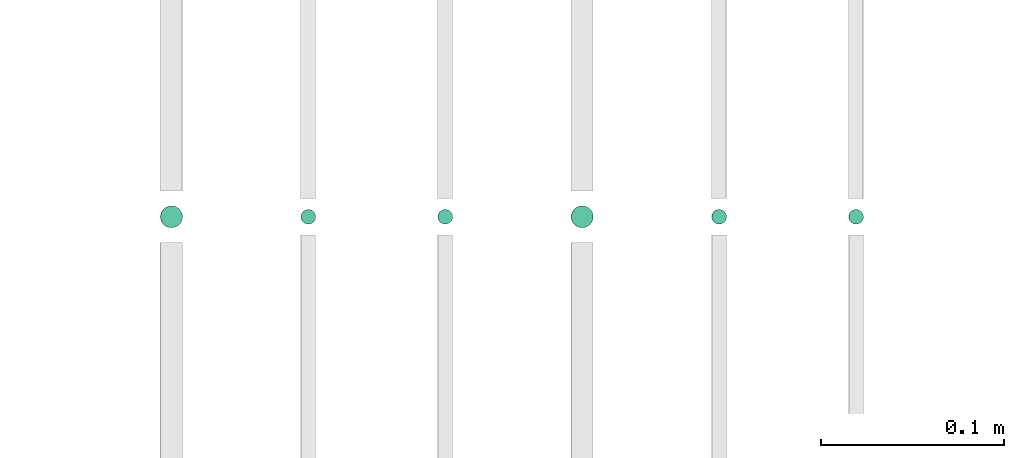
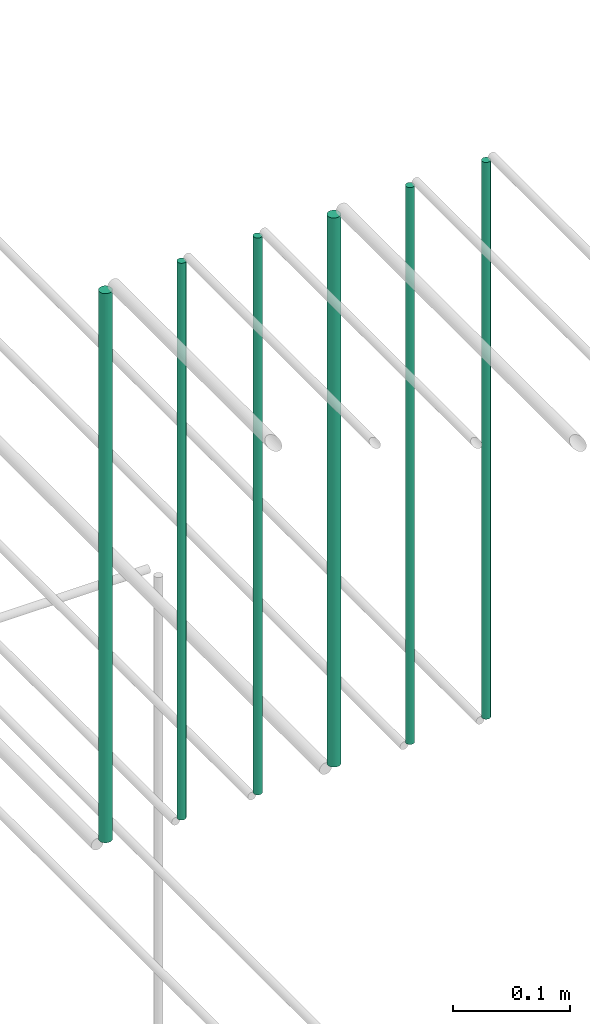
# One storey, part 140 of 331: 6 flow segments.
"""IFC2X3 building model written with IfcOpenShell, lengths in millimetres."""

from ifc_helpers import new_model, entity, si_unit, converted_unit, derived_unit, direction, frame, frame_2d, origin, origin_2d_with_axis, place, context, subcontext, project, spatial, circle, extrude, type_object, element, save


model = new_model("IFC2X3")

# Units and contexts
model_context = context("Model", 3, precision=0.01, world=origin(), true_north=direction((6.12303176911189e-17, 1.0)))
body_context = subcontext(model_context, "Body", "Model", "MODEL_VIEW")
ifc_project = project(units=[si_unit("LENGTHUNIT", "METRE", prefix="MILLI"), si_unit("AREAUNIT", "SQUARE_METRE"), si_unit("VOLUMEUNIT", "CUBIC_METRE"), converted_unit("PLANEANGLEUNIT", "DEGREE", entity("IfcRatioMeasure", 0.0174532925199433), si_unit("PLANEANGLEUNIT", "RADIAN"), dimensions=[0, 0, 0, 0, 0, 0, 0]), si_unit("MASSUNIT", "GRAM", prefix="KILO"), derived_unit("MASSDENSITYUNIT", [(si_unit("MASSUNIT", "GRAM", prefix="KILO"), 1), (si_unit("LENGTHUNIT", "METRE"), -3)]), derived_unit("MOMENTOFINERTIAUNIT", [(si_unit("LENGTHUNIT", "METRE"), 4)]), si_unit("TIMEUNIT", "SECOND"), si_unit("FREQUENCYUNIT", "HERTZ"), si_unit("THERMODYNAMICTEMPERATUREUNIT", "DEGREE_CELSIUS"), derived_unit("THERMALTRANSMITTANCEUNIT", [(si_unit("MASSUNIT", "GRAM", prefix="KILO"), 1), (si_unit("THERMODYNAMICTEMPERATUREUNIT", "KELVIN"), -1), (si_unit("TIMEUNIT", "SECOND"), -3)]), derived_unit("VOLUMETRICFLOWRATEUNIT", [(si_unit("LENGTHUNIT", "METRE"), 3), (si_unit("TIMEUNIT", "SECOND"), -1)]), derived_unit("MASSFLOWRATEUNIT", [(si_unit("MASSUNIT", "GRAM", prefix="KILO"), 1), (si_unit("TIMEUNIT", "SECOND"), -1)]), derived_unit("ROTATIONALFREQUENCYUNIT", [(si_unit("TIMEUNIT", "SECOND"), -1)]), si_unit("ELECTRICCURRENTUNIT", "AMPERE"), si_unit("ELECTRICVOLTAGEUNIT", "VOLT"), si_unit("POWERUNIT", "WATT"), si_unit("FORCEUNIT", "NEWTON", prefix="KILO"), si_unit("ILLUMINANCEUNIT", "LUX"), si_unit("LUMINOUSFLUXUNIT", "LUMEN"), si_unit("LUMINOUSINTENSITYUNIT", "CANDELA"), derived_unit("USERDEFINED", [(si_unit("MASSUNIT", "GRAM", prefix="KILO"), -1), (si_unit("LENGTHUNIT", "METRE"), -2), (si_unit("TIMEUNIT", "SECOND"), 3), (si_unit("LUMINOUSFLUXUNIT", "LUMEN"), 1)]), derived_unit("LINEARVELOCITYUNIT", [(si_unit("LENGTHUNIT", "METRE"), 1), (si_unit("TIMEUNIT", "SECOND"), -1)]), si_unit("PRESSUREUNIT", "PASCAL"), derived_unit("USERDEFINED", [(si_unit("LENGTHUNIT", "METRE"), -2), (si_unit("MASSUNIT", "GRAM", prefix="KILO"), 1), (si_unit("TIMEUNIT", "SECOND"), -2)]), derived_unit("LINEARFORCEUNIT", [(si_unit("MASSUNIT", "GRAM", prefix="KILO"), 1), (si_unit("LENGTHUNIT", "METRE"), 1), (si_unit("TIMEUNIT", "SECOND"), -2), (si_unit("LENGTHUNIT", "METRE"), -1)]), derived_unit("PLANARFORCEUNIT", [(si_unit("MASSUNIT", "GRAM", prefix="KILO"), 1), (si_unit("LENGTHUNIT", "METRE"), 1), (si_unit("TIMEUNIT", "SECOND"), -2), (si_unit("LENGTHUNIT", "METRE"), -2)])], contexts=[model_context])

# Site, building, storey
site_placement = place(None, frame((0.0, -0.00077364408347762, 0.0)))
site = spatial("IfcSite", under=ifc_project, at=site_placement, CompositionType="ELEMENT")
building_placement = place(site_placement, origin())
building = spatial("IfcBuilding", under=site, at=building_placement, CompositionType="ELEMENT")
storey_placement = place(building_placement, origin())
storey = spatial("IfcBuildingStorey", under=building, at=storey_placement, CompositionType="ELEMENT", Elevation=0.0)

# Flow segments
pipe_segment_type = type_object("IfcPipeSegmentType", PredefinedType="NOTDEFINED")
flow_segment_1_placement = place(storey_placement, frame((26465.733655358, 5638.02529159143, 18460.0)))
element("IfcFlowSegment", 1, at=flow_segment_1_placement, inside=storey, type_object=pipe_segment_type, context=body_context, shape_type="SweptSolid", body=[
    extrude(circle(Radius=4.0, at=origin_2d_with_axis()), frame((5.59527223591499, 5.59527223591607, 0.0), z_axis=(0.0, 0.0, 1.0), x_axis=(-1.0, 0.0, 0.0)), (0.0, 0.0, 1.0), 580.000000000015),
])
flow_segment_2_placement = place(storey_placement, frame((26390.733655358, 5638.02529159143, 18460.0)))
element("IfcFlowSegment", 2, at=flow_segment_2_placement, inside=storey, type_object=pipe_segment_type, context=body_context, shape_type="SweptSolid", body=[
    extrude(circle(Radius=4.0, at=origin_2d_with_axis()), frame((5.59527223591499, 5.59527223591607, 0.0), z_axis=(0.0, 0.0, 1.0), x_axis=(-1.0, 0.0, 0.0)), (0.0, 0.0, 1.0), 580.000000000007),
])
flow_segment_3_placement = place(storey_placement, frame((26313.733655358, 5636.02529159143, 18464.0)))
element("IfcFlowSegment", 3, at=flow_segment_3_placement, inside=storey, type_object=pipe_segment_type, context=body_context, shape_type="SweptSolid", body=[
    extrude(circle(Radius=6.0, at=origin_2d_with_axis()), frame((7.59527223591454, 7.59527223591562, 0.0), z_axis=(0.0, 0.0, 1.0), x_axis=(-1.0, 0.0, 0.0)), (0.0, 0.0, 1.0), 572.000000000002),
])
flow_segment_4_placement = place(storey_placement, frame((26240.733655358, 5638.02529159143, 18460.0)))
element("IfcFlowSegment", 4, at=flow_segment_4_placement, inside=storey, type_object=pipe_segment_type, context=body_context, shape_type="SweptSolid", body=[
    extrude(circle(Radius=4.0, at=origin_2d_with_axis()), frame((5.59527223591499, 5.59527223591607, 0.0), z_axis=(0.0, 0.0, 1.0), x_axis=(-1.0, 0.0, 0.0)), (0.0, 0.0, 1.0), 580.000000000015),
])
flow_segment_5_placement = place(storey_placement, frame((26165.733655358, 5638.02529159143, 18460.0)))
element("IfcFlowSegment", 5, at=flow_segment_5_placement, inside=storey, type_object=pipe_segment_type, context=body_context, shape_type="SweptSolid", body=[
    extrude(circle(Radius=4.0, at=frame_2d((0.0, -1.08286712929839e-12), x_axis=(1.0, 0.0))), frame((5.59527223591499, 5.59527223591499, 0.0), z_axis=(0.0, 0.0, 1.0), x_axis=(-1.0, 0.0, 0.0)), (0.0, 0.0, 1.0), 580.0),
])
flow_segment_6_placement = place(storey_placement, frame((26088.733655358, 5636.02529159144, 18464.0)))
element("IfcFlowSegment", 6, at=flow_segment_6_placement, inside=storey, type_object=pipe_segment_type, context=body_context, shape_type="SweptSolid", body=[
    extrude(circle(Radius=6.0, at=origin_2d_with_axis()), frame((7.59527223591454, 7.59527223591562, 0.0), z_axis=(0.0, 0.0, 1.0), x_axis=(-1.0, 0.0, 0.0)), (0.0, 0.0, 1.0), 572.000000000011),
])

save(model, "model.ifc")
